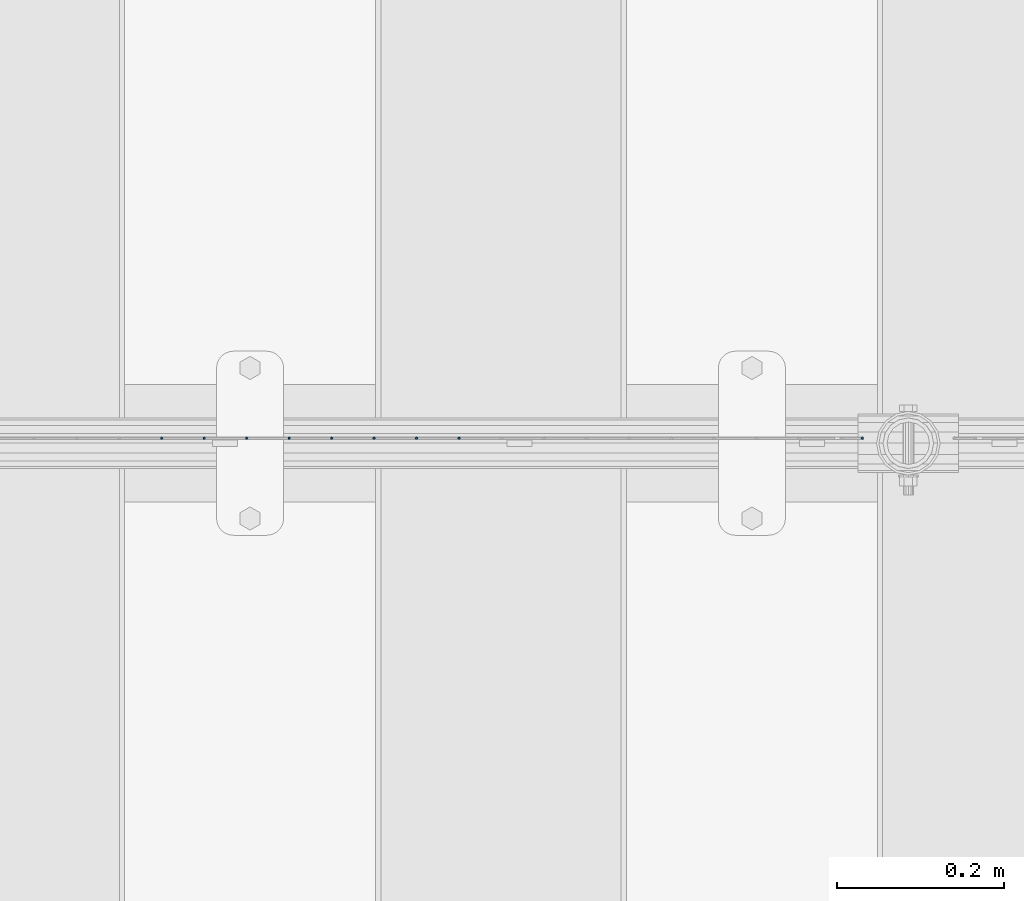
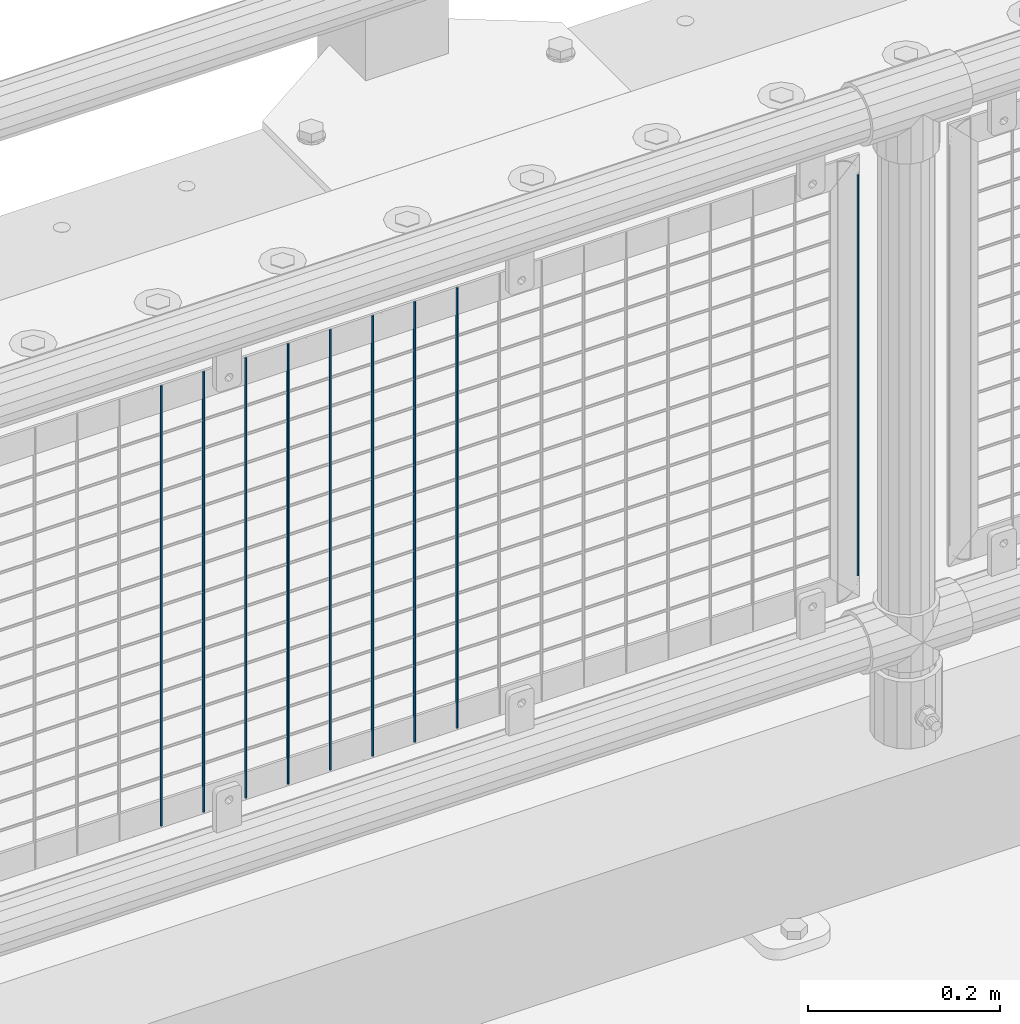
# One storey, part 68 of 242: 9 columns.
"""IFC2X3 building model written with IfcOpenShell, lengths in millimetres."""

from ifc_helpers import new_model, si_unit, frame, origin_with_axes, place, context, subcontext, project, spatial, faceted_brep, material, type_object, element, save


model = new_model("IFC2X3")

# Units and contexts
model_context = context("Model", 3, precision=1e-05, world=origin_with_axes())
body_context = subcontext(model_context, "Body", "Model", "MODEL_VIEW")
ifc_project = project(units=[si_unit("LENGTHUNIT", "METRE", prefix="MILLI"), si_unit("AREAUNIT", "SQUARE_METRE"), si_unit("VOLUMEUNIT", "CUBIC_METRE"), si_unit("MASSUNIT", "GRAM", prefix="KILO"), si_unit("TIMEUNIT", "SECOND"), si_unit("PLANEANGLEUNIT", "RADIAN"), si_unit("SOLIDANGLEUNIT", "STERADIAN"), si_unit("THERMODYNAMICTEMPERATUREUNIT", "DEGREE_CELSIUS"), si_unit("LUMINOUSINTENSITYUNIT", "LUMEN")], contexts=[model_context])

# Site, building, storey
site_placement = place(None, origin_with_axes())
site = spatial("IfcSite", under=ifc_project, at=site_placement, CompositionType="ELEMENT")
building_placement = place(site_placement, origin_with_axes())
building = spatial("IfcBuilding", under=site, at=building_placement, Name="Standard", CompositionType="ELEMENT")
storey_placement = place(building_placement, origin_with_axes())
storey = spatial("IfcBuildingStorey", under=building, at=storey_placement, Name="Undefined", CompositionType="ELEMENT", Elevation=0.0)

# Columns
ifc_material = material(Name="Misc_Undefined")
column_type = type_object("IfcColumnType", Name="D3", PredefinedType="NOTDEFINED")
for number, where, z_axis, x_axis in (
    (1, (-39100.14, -19329.5, 353.02), (-1.0, 0.0, 0.0), (0.0, 0.0, 1.0)),
    (2, (-39150.933, -19329.5, 353.02), (-1.0, 0.0, 0.0), (0.0, 0.0, 1.0)),
    (3, (-39201.726, -19329.5, 353.02), (-1.0, 0.0, 0.0), (0.0, 0.0, 1.0)),
    (4, (-39252.519, -19329.5, 353.02), (-1.0, 0.0, 0.0), (0.0, 0.0, 1.0)),
    (5, (-39303.312, -19329.5, 353.02), (-1.0, 0.0, 0.0), (0.0, 0.0, 1.0)),
    (6, (-39354.105, -19329.5, 353.02), (-1.0, 0.0, 0.0), (0.0, 0.0, 1.0)),
    (7, (-39404.898, -19329.5, 353.02), (-1.0, 0.0, 0.0), (0.0, 0.0, 1.0)),
    (8, (-39455.691, -19329.5, 353.02), (-1.0, 0.0, 0.0), (0.0, 0.0, 1.0)),
):
    element("IfcColumn", number, at=place(storey_placement, frame(where, z_axis=z_axis, x_axis=x_axis)), inside=storey, type_object=column_type, material=ifc_material, ObjectType="D3", context=body_context, shape_type="Brep", body=[
        faceted_brep([(0.0, -1.50000000000364, 0.0), (-3.63797880709171e-12, -0.750000000003638, -1.29903810567669), (560.0, -0.75, -1.29903810567703), (560.0, -1.5, 0.0), (0.0, 0.749999999996362, -1.29903810567669), (560.0, 0.75, -1.29903810567703), (-3.63797880709171e-12, 1.49999999999636, 0.0), (560.0, 1.5, 0.0), (0.0, 0.749999999996362, 1.29903810567669), (560.0, 0.75, 1.29903810567703), (-3.63797880709171e-12, -0.750000000003638, 1.29903810567669), (560.0, -0.75, 1.29903810567703)], [[[0, 1, 2, 3]], [[1, 4, 5, 2]], [[4, 6, 7, 5]], [[6, 8, 9, 7]], [[8, 10, 11, 9]], [[10, 0, 3, 11]], [[5, 7, 9, 11, 3, 2]], [[10, 8, 6, 4, 1, 0]]]),
    ])
column_placement = place(storey_placement, frame((-38618.0, -19329.5, 378.02), z_axis=(-1.0, 0.0, 0.0), x_axis=(0.0, 0.0, 1.0)))
element("IfcColumn", 9, at=column_placement, inside=storey, type_object=column_type, material=ifc_material, ObjectType="D3", context=body_context, shape_type="Brep", body=[
    faceted_brep([(0.0, -1.50000000000364, 0.0), (-3.63797880709171e-12, -0.750000000003638, -1.29903810567669), (510.0, -0.75, -1.29903810567703), (510.0, -1.5, 0.0), (0.0, 0.749999999996362, -1.29903810567669), (510.0, 0.75, -1.29903810567703), (-3.63797880709171e-12, 1.49999999999636, 0.0), (510.0, 1.5, 0.0), (0.0, 0.749999999996362, 1.29903810567669), (510.0, 0.75, 1.29903810567703), (-3.63797880709171e-12, -0.750000000003638, 1.29903810567669), (510.0, -0.75, 1.29903810567703)], [[[0, 1, 2, 3]], [[1, 4, 5, 2]], [[4, 6, 7, 5]], [[6, 8, 9, 7]], [[8, 10, 11, 9]], [[10, 0, 3, 11]], [[5, 7, 9, 11, 3, 2]], [[10, 8, 6, 4, 1, 0]]]),
])

save(model, "model.ifc")
